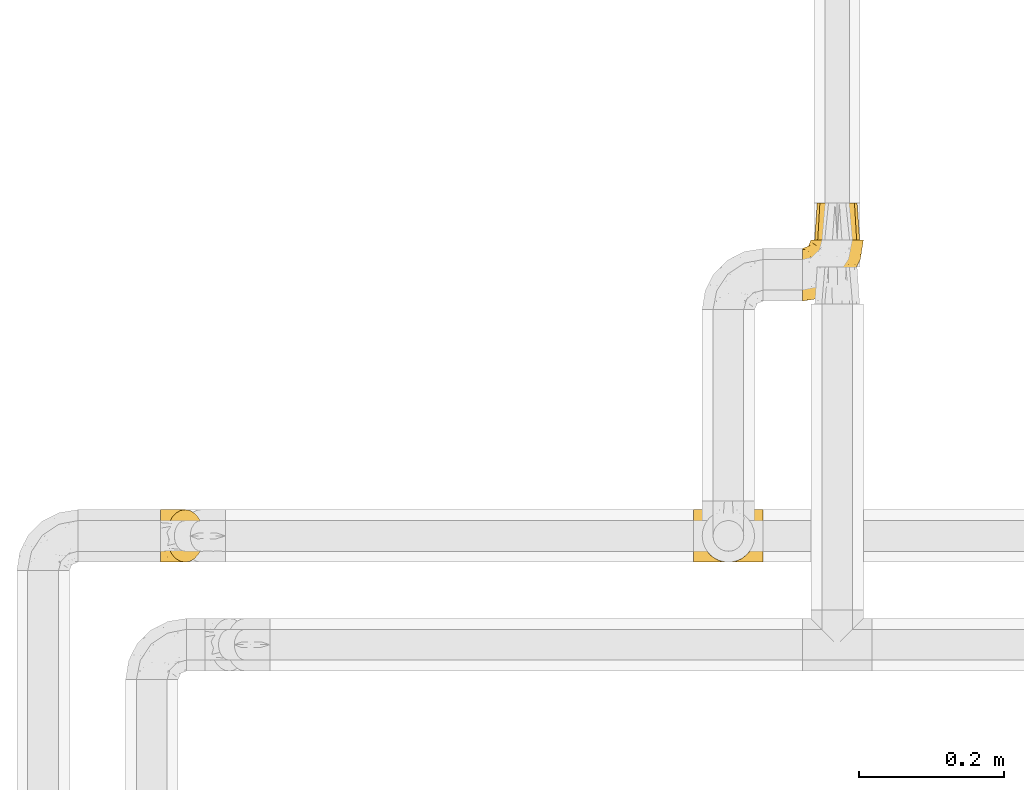
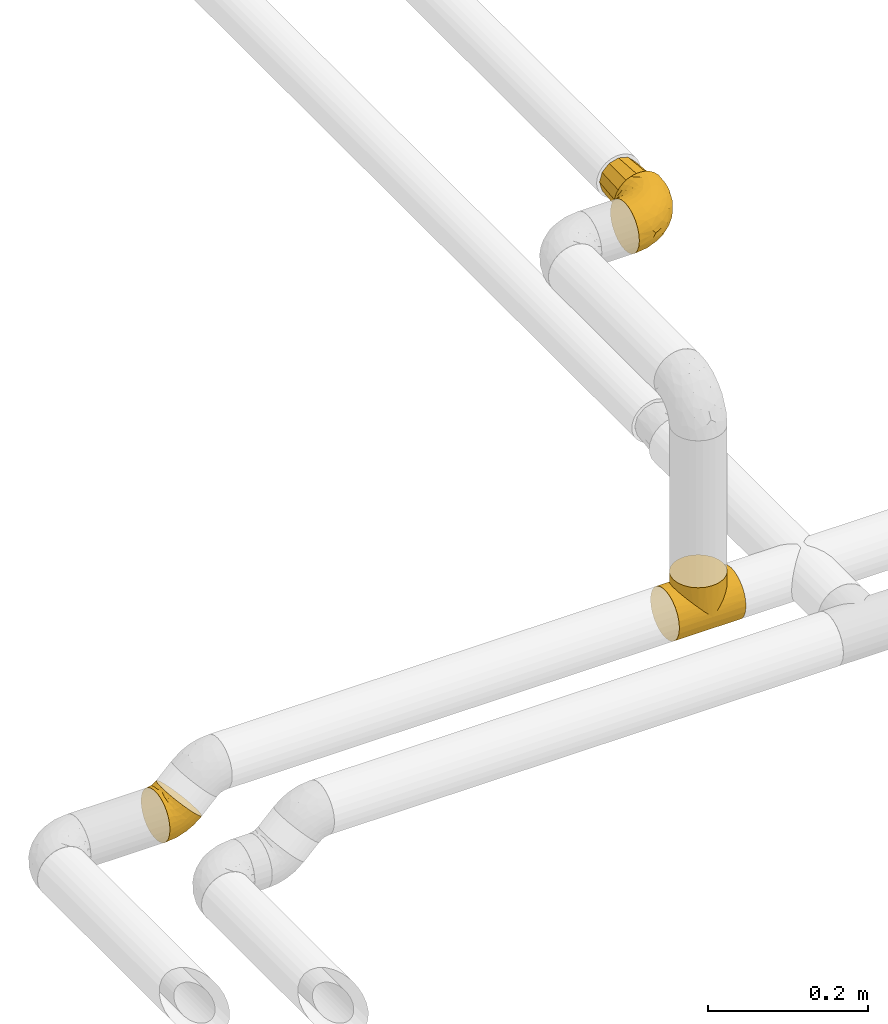
# One storey, part 20 of 39: 4 coverings.
"""IFC2X3 building model written with IfcOpenShell, lengths in millimetres."""

from ifc_helpers import new_model, entity, si_unit, converted_unit, derived_unit, direction, frame, origin, place, context, subcontext, project, spatial, faceted_brep, element, save


model = new_model("IFC2X3")

# Units and contexts
model_context = context("Model", 3, precision=0.01, world=origin(), true_north=direction((6.12303176911189e-17, 1.0)))
body_context = subcontext(model_context, "Body", "Model", "MODEL_VIEW")
ifc_project = project(units=[si_unit("LENGTHUNIT", "METRE", prefix="MILLI"), si_unit("AREAUNIT", "SQUARE_METRE"), si_unit("VOLUMEUNIT", "CUBIC_METRE"), converted_unit("PLANEANGLEUNIT", "DEGREE", entity("IfcRatioMeasure", 0.0174532925199433), si_unit("PLANEANGLEUNIT", "RADIAN"), dimensions=[0, 0, 0, 0, 0, 0, 0]), si_unit("MASSUNIT", "GRAM", prefix="KILO"), derived_unit("MASSDENSITYUNIT", [(si_unit("MASSUNIT", "GRAM", prefix="KILO"), 1), (si_unit("LENGTHUNIT", "METRE"), -3)]), derived_unit("MOMENTOFINERTIAUNIT", [(si_unit("LENGTHUNIT", "METRE"), 4)]), si_unit("TIMEUNIT", "SECOND"), si_unit("FREQUENCYUNIT", "HERTZ"), si_unit("THERMODYNAMICTEMPERATUREUNIT", "DEGREE_CELSIUS"), derived_unit("THERMALTRANSMITTANCEUNIT", [(si_unit("MASSUNIT", "GRAM", prefix="KILO"), 1), (si_unit("THERMODYNAMICTEMPERATUREUNIT", "KELVIN"), -1), (si_unit("TIMEUNIT", "SECOND"), -3)]), derived_unit("VOLUMETRICFLOWRATEUNIT", [(si_unit("LENGTHUNIT", "METRE"), 3), (si_unit("TIMEUNIT", "SECOND"), -1)]), derived_unit("MASSFLOWRATEUNIT", [(si_unit("MASSUNIT", "GRAM", prefix="KILO"), 1), (si_unit("TIMEUNIT", "SECOND"), -1)]), derived_unit("ROTATIONALFREQUENCYUNIT", [(si_unit("TIMEUNIT", "SECOND"), -1)]), si_unit("ELECTRICCURRENTUNIT", "AMPERE"), si_unit("ELECTRICVOLTAGEUNIT", "VOLT"), si_unit("POWERUNIT", "WATT"), si_unit("FORCEUNIT", "NEWTON", prefix="KILO"), si_unit("ILLUMINANCEUNIT", "LUX"), si_unit("LUMINOUSFLUXUNIT", "LUMEN"), si_unit("LUMINOUSINTENSITYUNIT", "CANDELA"), derived_unit("USERDEFINED", [(si_unit("MASSUNIT", "GRAM", prefix="KILO"), -1), (si_unit("LENGTHUNIT", "METRE"), -2), (si_unit("TIMEUNIT", "SECOND"), 3), (si_unit("LUMINOUSFLUXUNIT", "LUMEN"), 1)]), derived_unit("LINEARVELOCITYUNIT", [(si_unit("LENGTHUNIT", "METRE"), 1), (si_unit("TIMEUNIT", "SECOND"), -1)]), si_unit("PRESSUREUNIT", "PASCAL"), derived_unit("USERDEFINED", [(si_unit("LENGTHUNIT", "METRE"), -2), (si_unit("MASSUNIT", "GRAM", prefix="KILO"), 1), (si_unit("TIMEUNIT", "SECOND"), -2)]), derived_unit("LINEARFORCEUNIT", [(si_unit("MASSUNIT", "GRAM", prefix="KILO"), 1), (si_unit("LENGTHUNIT", "METRE"), 1), (si_unit("TIMEUNIT", "SECOND"), -2), (si_unit("LENGTHUNIT", "METRE"), -1)]), derived_unit("PLANARFORCEUNIT", [(si_unit("MASSUNIT", "GRAM", prefix="KILO"), 1), (si_unit("LENGTHUNIT", "METRE"), 1), (si_unit("TIMEUNIT", "SECOND"), -2), (si_unit("LENGTHUNIT", "METRE"), -2)])], contexts=[model_context])

# Site, building, storey
site_placement = place(None, origin())
site = spatial("IfcSite", under=ifc_project, at=site_placement, CompositionType="ELEMENT")
building_placement = place(site_placement, origin())
building = spatial("IfcBuilding", under=site, at=building_placement, CompositionType="ELEMENT")
storey_placement = place(building_placement, frame((0.0, 0.0, 24000.0)))
storey = spatial("IfcBuildingStorey", under=building, at=storey_placement, Name="07", CompositionType="ELEMENT", Elevation=24000.0)

# Coverings
covering_1_placement = place(storey_placement, frame((68680.48, 2837.56, 2992.18)))
element("IfcCovering", 1, at=covering_1_placement, inside=storey, Name=":ADSK_", ObjectType=":ADSK_", PredefinedType="INSULATION", context=body_context, shape_type="Brep", body=[
    faceted_brep([(1.61, 70.41, 53.5), (1.61, 73.09, 45.85), (1.6, 74.0, 37.8), (1.6, 73.09, 29.74), (1.6, 70.41, 22.08), (1.6, 66.09, 15.22), (1.6, 60.36, 9.49), (1.6, 53.5, 5.18), (1.6, 45.85, 2.5), (1.6, 37.8, 1.6), (1.6, 29.74, 2.5), (1.6, 22.08, 5.18), (1.6, 15.22, 9.5), (1.6, 9.49, 15.23), (1.6, 5.18, 22.09), (1.6, 2.5, 29.74), (1.6, 1.6, 37.8), (1.6, 2.5, 45.85), (1.61, 5.18, 53.51), (1.61, 9.5, 60.37), (1.61, 15.23, 66.1), (1.61, 22.09, 70.41), (1.61, 29.75, 73.09), (1.61, 37.8, 74.0), (1.61, 45.86, 73.09), (1.61, 53.51, 70.41), (1.61, 60.37, 66.09), (1.61, 66.1, 60.36), (35.55, 74.0, 51.85), (28.93, 72.76, 58.48), (22.75, 69.15, 64.65), (17.45, 63.39, 69.95), (13.39, 55.9, 74.02), (10.83, 47.17, 76.58), (9.96, 37.8, 77.45), (10.83, 28.43, 76.58), (13.39, 19.7, 74.02), (17.45, 12.2, 69.95), (22.75, 6.45, 64.65), (28.93, 2.83, 58.48), (35.55, 1.6, 51.85), (42.17, 2.83, 45.22), (48.35, 6.44, 39.05), (53.65, 12.2, 33.75), (57.72, 19.69, 29.68), (60.27, 28.43, 27.12), (61.15, 37.79, 26.25), (60.27, 47.16, 27.12), (57.72, 55.89, 29.68), (53.65, 63.39, 33.75), (48.35, 69.15, 39.05), (42.18, 72.76, 45.22), (18.39, 62.67, 13.41), (43.7, 37.8, 12.87), (50.18, 46.33, 18.27), (44.59, 59.22, 21.69), (23.39, 37.8, 4.46), (38.67, 47.22, 11.58), (41.04, 65.01, 25.7), (19.86, 49.2, 5.49), (31.54, 55.86, 12.28), (27.45, 67.36, 21.94), (32.38, 61.8, 17.29), (34.38, 70.8, 32.14), (28.93, 73.25, 37.71), (18.25, 71.45, 26.76), (47.67, 52.48, 19.06), (19.98, 74.0, 41.45), (15.02, 73.45, 33.24), (15.75, 56.5, 8.08), (13.47, 67.97, 18.84), (7.06, 74.0, 38.88), (12.52, 74.0, 39.96), (26.3, 74.0, 45.67), (30.92, 74.0, 48.76), (5.55, 44.65, 73.98), (6.54, 51.39, 72.21), (14.21, 71.74, 52.69), (18.21, 73.38, 47.93), (13.06, 73.3, 46.5), (11.6, 67.05, 61.05), (19.18, 72.18, 53.59), (17.71, 68.39, 62.09), (13.62, 63.72, 66.49), (24.23, 72.43, 55.92), (7.2, 73.06, 46.39), (10.05, 55.96, 71.4), (7.85, 59.5, 67.82), (8.72, 70.61, 53.87), (6.17, 65.15, 61.93), (6.13, 37.8, 74.89), (10.05, 19.65, 71.41), (13.63, 11.87, 66.49), (26.3, 1.6, 45.67), (19.18, 3.41, 53.59), (18.2, 2.21, 47.93), (6.53, 24.21, 72.21), (7.06, 1.6, 38.88), (7.84, 16.11, 67.83), (24.22, 3.16, 55.92), (30.92, 1.6, 48.76), (17.71, 7.2, 62.1), (8.72, 4.99, 53.88), (14.21, 3.86, 52.71), (11.59, 8.55, 61.06), (7.2, 2.54, 46.4), (13.08, 2.29, 46.51), (7.32, 30.7, 74.67), (12.52, 1.6, 39.96), (6.17, 10.45, 61.95), (19.97, 1.6, 41.45), (28.94, 2.34, 37.73), (18.25, 4.14, 26.77), (34.37, 4.79, 32.15), (18.39, 12.91, 13.42), (15.75, 19.08, 8.08), (31.54, 19.72, 12.29), (19.86, 26.38, 5.49), (50.18, 29.25, 18.27), (15.03, 2.14, 33.24), (38.69, 28.36, 11.59), (41.03, 10.58, 25.7), (44.6, 16.37, 21.69), (47.68, 23.1, 19.07), (27.44, 8.22, 21.95), (13.47, 7.62, 18.85), (32.38, 13.8, 17.28)], [[[0, 1, 2, 3, 4, 5, 6, 7, 8, 9, 10, 11, 12, 13, 14, 15, 16, 17, 18, 19, 20, 21, 22, 23, 24, 25, 26, 27]], [[28, 29, 30, 31, 32, 33, 34, 35, 36, 37, 38, 39, 40, 41, 42, 43, 44, 45, 46, 47, 48, 49, 50, 51]], [[5, 52, 6]], [[46, 53, 54]], [[48, 55, 49]], [[53, 56, 57]], [[58, 50, 49]], [[59, 60, 57]], [[61, 58, 62]], [[58, 63, 50]], [[64, 28, 51]], [[63, 61, 65]], [[54, 66, 47]], [[67, 64, 68]], [[55, 58, 49]], [[69, 52, 60]], [[59, 57, 56]], [[56, 8, 59]], [[7, 6, 69]], [[7, 69, 59]], [[65, 64, 63]], [[9, 8, 56]], [[70, 52, 5]], [[50, 63, 51]], [[60, 55, 66]], [[68, 2, 71, 72, 67]], [[4, 3, 65]], [[65, 61, 70]], [[59, 69, 60]], [[52, 69, 6]], [[4, 70, 5]], [[54, 57, 66]], [[3, 68, 65]], [[7, 59, 8]], [[64, 67, 73, 74, 28]], [[63, 64, 51]], [[66, 55, 48]], [[60, 52, 62]], [[65, 68, 64]], [[2, 68, 3]], [[62, 58, 55]], [[58, 61, 63]], [[60, 62, 55]], [[61, 62, 52]], [[47, 66, 48]], [[60, 66, 57]], [[65, 70, 4]], [[52, 70, 61]], [[46, 54, 47]], [[53, 57, 54]], [[75, 76, 24]], [[77, 78, 79]], [[80, 81, 77]], [[82, 83, 31]], [[84, 73, 81]], [[25, 24, 76]], [[85, 1, 0]], [[76, 75, 33]], [[86, 33, 32]], [[34, 33, 75]], [[86, 87, 76]], [[30, 84, 82]], [[78, 73, 67]], [[0, 88, 85]], [[89, 88, 27]], [[0, 27, 88]], [[85, 72, 71]], [[2, 1, 71]], [[29, 84, 30]], [[30, 82, 31]], [[73, 84, 74]], [[90, 75, 23]], [[72, 85, 79]], [[89, 87, 80]], [[25, 87, 26]], [[85, 71, 1]], [[25, 76, 87]], [[83, 32, 31]], [[77, 79, 88]], [[26, 89, 27]], [[67, 72, 79]], [[79, 85, 88]], [[87, 89, 26]], [[88, 89, 80]], [[81, 80, 82]], [[83, 82, 80]], [[80, 77, 88]], [[78, 77, 81]], [[80, 87, 83]], [[83, 87, 86]], [[73, 78, 81]], [[79, 78, 67]], [[29, 74, 84]], [[82, 84, 81]], [[29, 28, 74]], [[23, 75, 24]], [[75, 90, 34]], [[33, 86, 76]], [[83, 86, 32]], [[36, 91, 92]], [[93, 94, 95]], [[22, 21, 96]], [[17, 16, 97]], [[91, 35, 96]], [[21, 20, 98]], [[99, 100, 39]], [[101, 38, 37]], [[102, 103, 104]], [[94, 99, 101]], [[102, 105, 106]], [[91, 96, 98]], [[34, 90, 107]], [[103, 95, 94]], [[90, 23, 22]], [[92, 91, 98]], [[96, 21, 98]], [[97, 108, 105]], [[99, 39, 38]], [[98, 20, 109]], [[109, 20, 19]], [[102, 19, 18]], [[92, 104, 101]], [[17, 105, 18]], [[106, 103, 102]], [[105, 17, 97]], [[107, 96, 35]], [[109, 102, 104]], [[102, 18, 105]], [[96, 107, 22]], [[108, 110, 106]], [[106, 105, 108]], [[102, 109, 19]], [[98, 109, 104]], [[92, 101, 37]], [[104, 94, 101]], [[95, 106, 110]], [[104, 103, 94]], [[36, 92, 37]], [[98, 104, 92]], [[106, 95, 103]], [[93, 95, 110]], [[101, 99, 38]], [[93, 99, 94]], [[100, 99, 93]], [[100, 40, 39]], [[35, 91, 36]], [[34, 107, 35]], [[22, 107, 90]], [[111, 112, 113]], [[114, 115, 116]], [[111, 40, 100, 93, 110]], [[114, 13, 12]], [[117, 115, 11]], [[42, 41, 113]], [[45, 118, 46]], [[111, 110, 119]], [[117, 120, 116]], [[111, 113, 41]], [[121, 42, 113]], [[44, 122, 123]], [[40, 111, 41]], [[43, 122, 44]], [[14, 112, 15]], [[113, 124, 121]], [[112, 14, 125]], [[45, 123, 118]], [[125, 14, 13]], [[113, 112, 124]], [[112, 111, 119]], [[124, 125, 114]], [[120, 117, 56]], [[115, 12, 11]], [[10, 9, 56]], [[120, 56, 53]], [[10, 56, 117]], [[115, 117, 116]], [[115, 114, 12]], [[10, 117, 11]], [[126, 116, 122]], [[119, 16, 15]], [[123, 45, 44]], [[122, 121, 126]], [[121, 122, 43]], [[123, 116, 120]], [[119, 110, 108, 97, 16]], [[112, 119, 15]], [[42, 121, 43]], [[126, 124, 114]], [[124, 126, 121]], [[116, 126, 114]], [[116, 123, 122]], [[123, 120, 118]], [[114, 125, 13]], [[112, 125, 124]], [[120, 53, 118]], [[46, 118, 53]]]),
])
covering_2_placement = place(storey_placement, frame((69565.42, 3197.56, 3362.2)))
element("IfcCovering", 2, at=covering_2_placement, inside=storey, Name=":ADSK_", ObjectType=":ADSK_", PredefinedType="INSULATION", context=body_context, shape_type="Brep", body=[
    faceted_brep([(49.6, 85.8, 74.0), (57.65, 85.8, 73.09), (65.31, 85.8, 70.41), (72.17, 85.8, 66.09), (77.9, 85.8, 60.36), (82.21, 85.8, 53.5), (84.89, 85.8, 45.85), (85.8, 85.8, 37.8), (84.89, 85.8, 29.74), (82.21, 85.8, 22.08), (77.89, 85.8, 15.22), (72.16, 85.8, 9.49), (65.3, 85.8, 5.18), (57.65, 85.8, 2.5), (49.6, 85.8, 1.6), (44.33, 85.8, 2.19), (41.54, 85.8, 2.5), (37.71, 85.8, 3.84), (33.88, 85.8, 5.18), (27.02, 85.8, 9.5), (21.29, 85.8, 15.23), (16.98, 85.8, 22.09), (14.3, 85.8, 29.74), (13.4, 85.8, 37.8), (14.3, 85.8, 45.85), (16.98, 85.8, 53.51), (21.3, 85.8, 60.37), (27.03, 85.8, 66.1), (33.89, 85.8, 70.41), (37.72, 85.8, 71.75), (41.54, 85.8, 73.09), (44.33, 85.8, 73.4), (1.6, 72.76, 28.43), (1.6, 69.15, 19.7), (1.6, 63.39, 12.2), (1.6, 59.64, 9.32), (1.6, 55.9, 6.45), (1.6, 51.53, 4.64), (1.6, 47.16, 2.83), (1.6, 43.08, 2.29), (1.6, 40.44, 1.94), (1.6, 37.8, 1.6), (1.6, 28.43, 2.83), (1.6, 19.7, 6.45), (1.6, 12.2, 12.2), (1.6, 6.45, 19.7), (1.6, 2.83, 28.43), (1.6, 1.6, 37.8), (1.6, 2.83, 47.16), (1.6, 6.45, 55.9), (1.6, 12.2, 63.39), (1.6, 19.7, 69.15), (1.6, 28.43, 72.76), (1.6, 37.8, 74.0), (1.6, 43.08, 73.3), (1.6, 47.16, 72.76), (1.6, 51.53, 70.95), (1.6, 55.9, 69.15), (1.6, 59.64, 66.27), (1.6, 63.39, 63.39), (1.6, 69.15, 55.9), (1.6, 72.76, 47.16), (1.6, 74.0, 37.8), (59.61, 27.78, 50.11), (60.4, 26.99, 37.8), (68.25, 36.07, 46.44), (27.61, 5.72, 37.8), (22.94, 4.9, 44.03), (19.4, 4.42, 37.8), (42.09, 13.52, 47.59), (33.53, 14.0, 57.17), (21.38, 6.28, 50.38), (16.47, 9.64, 58.65), (54.23, 70.93, 73.37), (38.23, 36.05, 71.27), (19.11, 24.02, 70.16), (36.76, 25.93, 66.97), (17.03, 32.56, 73.22), (19.96, 41.45, 74.0), (12.51, 39.97, 74.0), (9.78, 39.42, 74.0), (7.05, 38.88, 74.0), (21.71, 16.62, 64.86), (62.55, 71.64, 70.93), (75.89, 47.83, 45.19), (81.72, 65.91, 48.57), (74.04, 51.38, 54.32), (47.66, 52.81, 72.94), (45.94, 67.43, 74.0), (43.34, 63.53, 74.0), (40.74, 59.64, 74.0), (38.14, 55.75, 74.0), (35.54, 51.85, 74.0), (51.41, 41.26, 68.72), (30.21, 38.98, 73.34), (68.91, 70.65, 67.28), (74.03, 65.64, 61.7), (79.54, 71.08, 55.94), (82.98, 67.99, 37.8), (67.24, 38.62, 53.02), (55.48, 28.73, 57.31), (48.51, 80.34, 74.0), (47.42, 74.88, 74.0), (65.49, 52.52, 64.86), (64.99, 41.68, 59.15), (58.95, 56.44, 70.05), (45.7, 19.89, 55.98), (39.35, 11.7, 37.8), (53.72, 34.04, 63.54), (42.9, 22.66, 61.4), (81.67, 59.78, 37.8), (69.71, 36.3, 37.8), (75.69, 48.04, 37.8), (31.64, 49.25, 74.0), (27.75, 46.65, 74.0), (23.86, 44.05, 74.0), (51.09, 17.68, 37.8), (17.47, 56.47, 70.9), (18.36, 60.92, 69.2), (12.71, 63.29, 65.83), (7.84, 45.31, 73.31), (7.85, 59.83, 67.07), (6.14, 64.71, 62.53), (11.2, 74.49, 52.3), (14.99, 76.83, 54.94), (11.85, 78.01, 46.54), (23.69, 56.9, 72.08), (20.48, 50.18, 73.17), (14.49, 71.99, 59.32), (9.51, 70.83, 56.36), (6.6, 73.18, 48.99), (6.61, 68.29, 58.36), (26.46, 80.74, 66.05), (20.83, 78.17, 61.56), (28.69, 73.83, 68.98), (41.38, 76.96, 73.26), (7.16, 54.72, 70.05), (16.97, 47.37, 73.39), (12.64, 54.39, 70.87), (18.4, 74.3, 61.17), (35.97, 75.54, 71.9), (16.38, 66.46, 65.19), (11.31, 80.75, 37.8), (13.68, 81.71, 46.04), (15.78, 81.69, 52.15), (24.06, 72.63, 66.57), (9.94, 77.45, 37.8), (35.3, 62.19, 73.34), (36.41, 67.73, 72.91), (6.64, 76.08, 37.8), (10.52, 48.26, 72.75), (23.5, 62.83, 70.14), (29.62, 62.31, 72.14), (20.86, 68.86, 66.28), (29.66, 56.53, 73.22), (6.61, 68.29, 17.23), (6.59, 73.17, 26.6), (6.13, 64.71, 13.06), (48.51, 80.34, 1.6), (47.42, 74.88, 1.6), (13.67, 81.71, 29.56), (14.98, 76.83, 20.66), (15.78, 81.69, 23.45), (20.82, 78.17, 14.04), (12.51, 39.97, 1.6), (7.05, 38.88, 1.6), (4.32, 38.34, 1.6), (9.51, 70.83, 19.23), (11.19, 74.49, 23.3), (14.48, 72.0, 16.29), (10.19, 59.87, 8.09), (12.64, 54.39, 4.72), (7.16, 54.72, 5.54), (35.96, 75.53, 3.69), (10.52, 48.26, 2.84), (20.47, 50.18, 2.42), (17.47, 56.47, 4.69), (23.68, 56.9, 3.51), (16.97, 47.37, 2.2), (11.85, 78.01, 29.05), (7.84, 45.31, 2.29), (26.45, 80.74, 9.55), (18.39, 74.3, 14.43), (41.37, 76.96, 2.33), (29.62, 62.32, 3.45), (29.66, 56.54, 2.37), (23.5, 62.83, 5.45), (16.36, 66.46, 10.41), (35.87, 67.82, 2.81), (28.67, 73.83, 6.62), (45.94, 67.43, 1.6), (12.7, 63.29, 9.76), (24.04, 72.63, 9.03), (38.14, 55.75, 1.6), (30.95, 67.39, 4.15), (35.8, 62.12, 2.17), (43.34, 63.53, 1.6), (27.75, 46.65, 1.6), (31.64, 49.25, 1.6), (19.96, 41.45, 1.6), (23.86, 44.05, 1.6), (18.36, 60.93, 6.39), (20.85, 68.85, 9.32), (40.74, 59.64, 1.6), (35.54, 51.85, 1.6), (38.23, 36.06, 4.32), (17.03, 32.56, 2.37), (30.2, 38.98, 2.25), (64.98, 41.69, 16.43), (55.47, 28.73, 18.27), (53.71, 34.05, 12.04), (36.76, 25.93, 8.62), (51.4, 41.26, 6.87), (65.48, 52.53, 10.72), (47.66, 52.81, 2.64), (59.61, 27.78, 25.48), (45.69, 19.9, 19.59), (19.11, 24.02, 5.43), (22.94, 4.9, 31.57), (21.39, 6.28, 25.21), (58.94, 56.45, 5.53), (16.47, 9.64, 16.94), (21.71, 16.62, 10.73), (33.54, 14.0, 18.42), (74.04, 51.38, 21.26), (81.72, 65.91, 27.01), (75.89, 47.82, 30.39), (54.23, 70.94, 2.22), (74.02, 65.64, 13.88), (68.9, 70.65, 8.3), (42.09, 13.52, 28.0), (68.25, 36.08, 29.14), (67.24, 38.62, 22.56), (79.54, 71.07, 19.64), (42.91, 22.68, 14.18), (62.54, 71.64, 4.66)], [[[0, 1, 2, 3, 4, 5, 6, 7, 8, 9, 10, 11, 12, 13, 14, 15, 16, 17, 18, 19, 20, 21, 22, 23, 24, 25, 26, 27, 28, 29, 30, 31]], [[32, 33, 34, 35, 36, 37, 38, 39, 40, 41, 42, 43, 44, 45, 46, 47, 48, 49, 50, 51, 52, 53, 54, 55, 56, 57, 58, 59, 60, 61, 62]], [[63, 64, 65]], [[66, 67, 68]], [[69, 70, 71]], [[71, 70, 72]], [[73, 1, 0]], [[74, 75, 76]], [[49, 48, 71]], [[77, 78, 79, 80, 81, 53]], [[50, 82, 51]], [[72, 50, 49]], [[2, 1, 83]], [[84, 85, 86]], [[87, 88, 89, 90, 91, 92]], [[53, 52, 77]], [[93, 74, 76]], [[5, 85, 6]], [[94, 78, 77]], [[95, 3, 2]], [[95, 96, 3]], [[75, 51, 82]], [[85, 5, 97]], [[50, 72, 82]], [[97, 5, 4]], [[85, 98, 6]], [[94, 87, 92]], [[74, 77, 75]], [[99, 100, 63]], [[96, 4, 3]], [[73, 0, 101, 102, 88]], [[96, 103, 104]], [[48, 68, 67]], [[84, 99, 65]], [[105, 83, 73]], [[105, 95, 83]], [[100, 106, 63]], [[86, 96, 104]], [[97, 86, 85]], [[67, 107, 69]], [[100, 108, 109]], [[84, 110, 85]], [[93, 87, 74]], [[96, 95, 103]], [[69, 71, 67]], [[70, 69, 106]], [[4, 96, 97]], [[86, 97, 96]], [[83, 95, 2]], [[103, 95, 105]], [[93, 103, 105]], [[103, 108, 104]], [[75, 77, 52]], [[94, 77, 74]], [[51, 75, 52]], [[75, 82, 76]], [[109, 82, 70]], [[93, 76, 108]], [[88, 87, 73]], [[105, 73, 87]], [[84, 86, 99]], [[84, 111, 112, 110]], [[98, 85, 110]], [[98, 7, 6]], [[73, 83, 1]], [[71, 72, 49]], [[82, 72, 70]], [[87, 94, 74]], [[94, 92, 113, 114, 115, 78]], [[48, 47, 68]], [[48, 67, 71]], [[100, 104, 108]], [[99, 86, 104]], [[109, 108, 76]], [[100, 109, 106]], [[82, 109, 76]], [[106, 109, 70]], [[100, 99, 104]], [[99, 63, 65]], [[69, 116, 63]], [[111, 84, 65]], [[64, 63, 116]], [[64, 111, 65]], [[63, 106, 69]], [[103, 93, 108]], [[87, 93, 105]], [[107, 67, 66]], [[107, 116, 69]], [[117, 118, 119]], [[80, 120, 55]], [[121, 119, 122]], [[120, 56, 55]], [[123, 124, 125]], [[114, 126, 127]], [[101, 0, 31, 30, 102]], [[123, 128, 124]], [[129, 123, 130]], [[60, 122, 131]], [[132, 133, 134]], [[29, 28, 135]], [[131, 61, 60]], [[122, 60, 59]], [[136, 137, 138]], [[124, 128, 139]], [[132, 27, 26]], [[131, 130, 61]], [[140, 135, 28]], [[102, 29, 135]], [[119, 118, 141]], [[58, 136, 121]], [[140, 28, 27]], [[54, 53, 81, 80, 55]], [[23, 142, 143]], [[24, 144, 25]], [[25, 144, 133]], [[26, 25, 133]], [[134, 133, 145]], [[125, 142, 146]], [[124, 143, 125]], [[147, 90, 148]], [[124, 144, 143]], [[149, 125, 146]], [[150, 57, 56]], [[137, 78, 115]], [[130, 62, 61]], [[132, 140, 27]], [[151, 152, 153]], [[140, 134, 148]], [[148, 89, 140]], [[120, 78, 150]], [[115, 127, 137]], [[137, 136, 150]], [[78, 120, 80, 79]], [[150, 56, 120]], [[91, 154, 92]], [[127, 117, 138]], [[144, 24, 143]], [[133, 144, 124]], [[152, 91, 147]], [[145, 152, 134]], [[23, 143, 24]], [[142, 125, 143]], [[130, 125, 149]], [[128, 123, 129]], [[141, 129, 119]], [[124, 139, 133]], [[125, 130, 123]], [[62, 130, 149]], [[128, 153, 139]], [[145, 139, 153]], [[92, 154, 113]], [[127, 115, 114]], [[117, 127, 126]], [[118, 117, 126]], [[121, 117, 119]], [[138, 137, 127]], [[78, 137, 150]], [[151, 118, 126]], [[118, 151, 141]], [[153, 128, 141]], [[129, 141, 128]], [[102, 30, 29]], [[140, 88, 135]], [[88, 102, 135]], [[133, 132, 26]], [[140, 132, 134]], [[121, 122, 59]], [[131, 119, 129]], [[121, 59, 58]], [[121, 138, 117]], [[136, 58, 57]], [[150, 136, 57]], [[121, 136, 138]], [[119, 131, 122]], [[131, 129, 130]], [[139, 145, 133]], [[152, 145, 153]], [[89, 148, 90]], [[89, 88, 140]], [[147, 134, 152]], [[134, 147, 148]], [[126, 114, 113]], [[152, 154, 91]], [[91, 90, 147]], [[151, 153, 141]], [[154, 151, 126]], [[151, 154, 152]], [[113, 154, 126]], [[155, 32, 156]], [[33, 157, 34]], [[62, 149, 156]], [[15, 14, 158, 159, 16]], [[160, 23, 22]], [[161, 162, 163]], [[40, 39, 38, 164, 165, 166, 41]], [[167, 168, 169]], [[157, 170, 34]], [[171, 172, 170]], [[18, 173, 19]], [[174, 37, 36]], [[175, 176, 177]], [[178, 171, 175]], [[146, 179, 149]], [[168, 179, 161]], [[161, 160, 162]], [[162, 160, 22]], [[38, 37, 180]], [[20, 19, 181]], [[21, 20, 163]], [[161, 182, 169]], [[18, 183, 173]], [[184, 185, 186]], [[169, 187, 167]], [[188, 189, 173]], [[159, 190, 183]], [[17, 159, 183]], [[156, 179, 168]], [[191, 157, 155]], [[192, 163, 189]], [[21, 162, 22]], [[146, 142, 179]], [[181, 163, 20]], [[185, 184, 193]], [[178, 172, 171]], [[167, 156, 168]], [[184, 194, 195]], [[181, 173, 189]], [[173, 196, 188]], [[197, 177, 198]], [[199, 164, 180]], [[180, 164, 38]], [[200, 178, 175]], [[37, 174, 180]], [[199, 180, 174]], [[175, 197, 200]], [[177, 176, 201]], [[163, 162, 21]], [[160, 161, 179]], [[192, 184, 202]], [[194, 189, 188]], [[179, 142, 160]], [[23, 160, 142]], [[169, 168, 161]], [[155, 156, 167]], [[182, 161, 163]], [[202, 186, 187]], [[62, 156, 32]], [[179, 156, 149]], [[192, 182, 163]], [[202, 169, 182]], [[176, 175, 171]], [[174, 178, 199]], [[197, 175, 177]], [[170, 176, 171]], [[201, 176, 191]], [[199, 178, 200]], [[178, 174, 172]], [[187, 201, 191]], [[201, 187, 186]], [[167, 187, 191]], [[169, 202, 187]], [[173, 183, 190]], [[17, 16, 159]], [[173, 181, 19]], [[163, 181, 189]], [[155, 157, 33]], [[170, 157, 191]], [[176, 170, 191]], [[35, 170, 172]], [[35, 172, 36]], [[34, 170, 35]], [[174, 36, 172]], [[32, 155, 33]], [[191, 155, 167]], [[192, 189, 194]], [[182, 192, 202]], [[185, 198, 177]], [[183, 18, 17]], [[196, 173, 190]], [[196, 203, 188]], [[201, 186, 177]], [[202, 184, 186]], [[188, 195, 194]], [[204, 185, 193]], [[188, 203, 195]], [[192, 194, 184]], [[203, 193, 195]], [[184, 195, 193]], [[198, 185, 204]], [[186, 185, 177]], [[205, 206, 207]], [[208, 209, 210]], [[210, 211, 212]], [[210, 213, 208]], [[214, 204, 193, 203, 196, 190]], [[206, 41, 166, 165, 164, 199]], [[215, 216, 209]], [[206, 217, 42]], [[218, 46, 219]], [[207, 214, 205]], [[212, 214, 220]], [[221, 219, 45]], [[45, 219, 46]], [[221, 222, 223]], [[224, 225, 226]], [[222, 44, 43]], [[222, 217, 211]], [[220, 214, 227]], [[227, 190, 159, 158, 14]], [[217, 43, 42]], [[14, 13, 227]], [[225, 9, 8]], [[10, 228, 11]], [[11, 229, 12]], [[208, 213, 228]], [[228, 229, 11]], [[230, 219, 223]], [[231, 232, 226]], [[231, 64, 215]], [[225, 233, 9]], [[229, 213, 220]], [[233, 10, 9]], [[110, 225, 98]], [[41, 206, 42]], [[222, 211, 234]], [[224, 228, 233]], [[225, 8, 98]], [[221, 45, 44]], [[226, 110, 112, 111]], [[12, 229, 235]], [[46, 218, 68]], [[230, 107, 218]], [[223, 234, 216]], [[107, 66, 218]], [[224, 233, 225]], [[228, 10, 233]], [[213, 229, 228]], [[235, 229, 220]], [[208, 228, 224]], [[212, 213, 210]], [[207, 206, 199]], [[205, 211, 217]], [[205, 217, 206]], [[43, 217, 222]], [[212, 211, 205]], [[210, 209, 234]], [[227, 13, 235]], [[214, 190, 227]], [[110, 226, 225]], [[232, 231, 215]], [[8, 7, 98]], [[227, 235, 220]], [[13, 12, 235]], [[222, 221, 44]], [[219, 221, 223]], [[207, 199, 200, 197, 198, 204]], [[214, 207, 204]], [[68, 218, 66]], [[68, 47, 46]], [[230, 218, 219]], [[224, 232, 208]], [[208, 232, 209]], [[216, 215, 230]], [[210, 234, 211]], [[216, 234, 209]], [[222, 234, 223]], [[226, 232, 224]], [[209, 232, 215]], [[226, 111, 231]], [[64, 116, 215]], [[231, 111, 64]], [[116, 230, 215]], [[230, 223, 216]], [[214, 212, 205]], [[213, 212, 220]], [[230, 116, 107]]]),
])
covering_3_placement = place(storey_placement, frame((69582.42, 3283.35, 3367.4)))
element("IfcCovering", 3, at=covering_3_placement, inside=storey, Name=":ADSK_", ObjectType=":ADSK_", PredefinedType="INSULATION", context=body_context, shape_type="Brep", body=[
    faceted_brep([(56.41, 51.0, 46.35), (58.25, 51.0, 39.47), (60.1, 51.0, 32.6), (58.25, 51.0, 25.72), (56.41, 51.0, 18.85), (51.38, 51.0, 13.81), (46.35, 51.0, 8.78), (39.47, 51.0, 6.94), (32.6, 51.0, 5.1), (25.72, 51.0, 6.94), (18.85, 51.0, 8.78), (13.81, 51.0, 13.81), (8.78, 51.0, 18.85), (6.94, 51.0, 25.72), (5.1, 51.0, 32.6), (6.94, 51.0, 39.47), (8.78, 51.0, 46.35), (13.81, 51.0, 51.38), (18.85, 51.0, 56.41), (25.72, 51.0, 58.25), (32.6, 51.0, 60.1), (39.47, 51.0, 58.25), (46.35, 51.0, 56.41), (51.38, 51.0, 51.38), (11.42, 0.0, 53.77), (5.75, 0.0, 48.1), (4.15, 0.0, 42.14), (1.6, 0.0, 32.6), (4.15, 0.0, 23.05), (5.75, 0.0, 17.1), (11.42, 0.0, 11.42), (17.1, 0.0, 5.75), (23.05, 0.0, 4.15), (32.6, 0.0, 1.6), (42.14, 0.0, 4.15), (48.1, 0.0, 5.75), (53.77, 0.0, 11.42), (59.44, 0.0, 17.1), (61.04, 0.0, 23.05), (63.6, 0.0, 32.6), (61.04, 0.0, 42.14), (59.44, 0.0, 48.1), (53.77, 0.0, 53.77), (48.1, 0.0, 59.44), (42.14, 0.0, 61.04), (32.6, 0.0, 63.6), (23.05, 0.0, 61.04), (17.1, 0.0, 59.44)], [[[0, 1, 2, 3, 4, 5, 6, 7, 8, 9, 10, 11, 12, 13, 14, 15, 16, 17, 18, 19, 20, 21, 22, 23]], [[24, 25, 26, 27, 28, 29, 30, 31, 32, 33, 34, 35, 36, 37, 38, 39, 40, 41, 42, 43, 44, 45, 46, 47]], [[6, 35, 34, 33, 8, 7]], [[37, 36, 35, 6, 5, 4]], [[3, 2, 39, 38, 37, 4]], [[12, 29, 28, 27, 14, 13]], [[31, 30, 29, 12, 11, 10]], [[9, 8, 33, 32, 31, 10]], [[18, 47, 46, 45, 20, 19]], [[25, 24, 47, 18, 17, 16]], [[15, 14, 27, 26, 25, 16]], [[0, 41, 40, 39, 2, 1]], [[43, 42, 41, 0, 23, 22]], [[21, 20, 45, 44, 43, 22]]]),
])
covering_4_placement = place(storey_placement, frame((69417.01, 2837.56, 3042.2)))
element("IfcCovering", 4, at=covering_4_placement, inside=storey, Name=":ADSK_", ObjectType=":ADSK_", PredefinedType="INSULATION", context=body_context, shape_type="Brep", body=[
    faceted_brep([(41.92, 73.48, 43.88), (0.0, 74.0, 37.8), (0.0, 72.76, 47.16), (0.0, 69.15, 55.9), (35.92, 71.92, 49.87), (24.64, 65.45, 61.15), (0.0, 63.39, 63.39), (30.12, 69.27, 55.68), (48.0, 74.0, 37.8), (54.08, 73.48, 43.88), (96.0, 74.0, 37.8), (19.71, 60.38, 66.09), (0.0, 55.9, 69.15), (15.62, 53.98, 70.18), (0.0, 47.16, 72.76), (12.82, 46.31, 72.98), (0.0, 37.8, 74.0), (11.8, 37.8, 74.0), (83.18, 46.31, 72.98), (84.2, 37.8, 74.0), (96.0, 37.8, 74.0), (12.81, 29.29, 72.98), (0.0, 28.43, 72.76), (15.61, 21.62, 70.18), (0.0, 19.7, 69.15), (19.7, 15.22, 66.09), (0.0, 12.2, 63.39), (83.19, 29.29, 72.98), (24.64, 10.14, 61.16), (30.11, 6.33, 55.69), (0.0, 6.45, 55.9), (35.92, 3.67, 49.88), (0.0, 2.83, 47.16), (41.91, 2.11, 43.88), (0.0, 1.6, 37.8), (48.0, 1.6, 37.8), (54.09, 2.11, 43.88), (96.0, 1.6, 37.8), (96.0, 37.8, 1.6), (96.0, 47.16, 2.83), (96.0, 55.9, 6.45), (96.0, 63.39, 12.2), (96.0, 69.15, 19.7), (96.0, 72.76, 28.43), (96.0, 72.76, 47.16), (96.0, 69.15, 55.9), (96.0, 63.39, 63.39), (96.0, 55.9, 69.15), (96.0, 47.16, 72.76), (96.0, 28.43, 72.76), (96.0, 19.7, 69.15), (96.0, 12.2, 63.39), (96.0, 6.45, 55.9), (96.0, 2.83, 47.16), (96.0, 2.83, 28.43), (96.0, 6.45, 19.7), (96.0, 12.2, 12.2), (96.0, 19.7, 6.45), (96.0, 28.43, 2.83), (0.0, 47.16, 2.83), (0.0, 37.8, 1.6), (0.0, 28.43, 2.83), (0.0, 19.7, 6.45), (0.0, 12.2, 12.2), (0.0, 6.45, 19.7), (0.0, 2.83, 28.43), (0.0, 72.76, 28.43), (0.0, 69.15, 19.7), (0.0, 63.39, 12.2), (0.0, 55.9, 6.45), (60.08, 71.92, 49.87), (65.88, 69.27, 55.68), (71.36, 65.45, 61.15), (76.29, 60.38, 66.09), (80.38, 53.98, 70.18), (80.39, 21.62, 70.18), (76.3, 15.22, 66.09), (71.36, 10.14, 61.16), (65.89, 6.33, 55.69), (60.08, 3.67, 49.88), (13.03, 47.16, 85.8), (11.8, 37.8, 85.8), (13.03, 28.43, 85.8), (16.65, 19.7, 85.8), (22.4, 12.2, 85.8), (29.9, 6.45, 85.8), (38.63, 2.83, 85.8), (48.0, 1.6, 85.8), (57.37, 2.83, 85.8), (66.1, 6.45, 85.8), (73.6, 12.2, 85.8), (79.35, 19.7, 85.8), (82.97, 28.43, 85.8), (84.2, 37.8, 85.8), (82.97, 47.16, 85.8), (79.35, 55.9, 85.8), (73.6, 63.39, 85.8), (66.1, 69.15, 85.8), (57.37, 72.76, 85.8), (48.0, 74.0, 85.8), (38.63, 72.76, 85.8), (29.9, 69.15, 85.8), (22.4, 63.39, 85.8), (16.65, 55.9, 85.8)], [[[0, 1, 2]], [[2, 3, 4]], [[5, 3, 6]], [[5, 7, 3]], [[0, 8, 1]], [[8, 9, 10]], [[7, 4, 3]], [[0, 2, 4]], [[11, 6, 12]], [[13, 12, 14]], [[15, 14, 16]], [[13, 11, 12]], [[17, 15, 16]], [[18, 19, 20]], [[13, 14, 15]], [[6, 11, 5]], [[21, 16, 22]], [[23, 22, 24]], [[25, 24, 26]], [[21, 17, 16]], [[19, 27, 20]], [[25, 23, 24]], [[21, 22, 23]], [[26, 28, 25]], [[29, 28, 30]], [[30, 28, 26]], [[31, 30, 32]], [[33, 32, 34]], [[31, 29, 30]], [[35, 33, 34]], [[36, 35, 37]], [[31, 32, 33]], [[38, 39, 40, 41, 42, 43, 10, 44, 45, 46, 47, 48, 20, 49, 50, 51, 52, 53, 37, 54, 55, 56, 57, 58]], [[59, 60, 61, 62, 63, 64, 65, 34, 32, 30, 26, 24, 22, 16, 14, 12, 6, 3, 2, 1, 66, 67, 68, 69]], [[69, 68, 41, 40]], [[38, 60, 59, 39]], [[59, 69, 40, 39]], [[42, 67, 66, 43]], [[1, 8, 10, 43, 66]], [[41, 68, 67, 42]], [[70, 71, 45]], [[9, 70, 44]], [[10, 9, 44]], [[45, 72, 46]], [[45, 44, 70]], [[72, 45, 71]], [[73, 74, 47]], [[74, 18, 48]], [[46, 73, 47]], [[47, 74, 48]], [[18, 20, 48]], [[73, 46, 72]], [[75, 76, 50]], [[27, 75, 49]], [[20, 27, 49]], [[50, 49, 75]], [[51, 50, 76]], [[76, 77, 51]], [[78, 79, 52]], [[79, 36, 53]], [[77, 52, 51]], [[77, 78, 52]], [[52, 79, 53]], [[36, 37, 53]], [[35, 34, 65, 54, 37]], [[54, 65, 64, 55]], [[64, 63, 56, 55]], [[56, 63, 62, 57]], [[57, 62, 61, 58]], [[58, 61, 60, 38]], [[80, 81, 82, 83, 84, 85, 86, 87, 88, 89, 90, 91, 92, 93, 94, 95, 96, 97, 98, 99, 100, 101, 102, 103]], [[15, 81, 80]], [[103, 102, 11]], [[13, 80, 103]], [[15, 17, 81]], [[11, 13, 103]], [[15, 80, 13]], [[102, 5, 11]], [[7, 5, 101]], [[101, 5, 102]], [[4, 101, 100]], [[0, 100, 99]], [[4, 7, 101]], [[8, 0, 99]], [[4, 100, 0]], [[9, 99, 98]], [[98, 97, 70]], [[72, 97, 96]], [[72, 71, 97]], [[9, 8, 99]], [[71, 70, 97]], [[9, 98, 70]], [[73, 96, 95]], [[74, 95, 94]], [[18, 94, 93]], [[74, 73, 95]], [[19, 18, 93]], [[74, 94, 18]], [[96, 73, 72]], [[27, 93, 92]], [[75, 92, 91]], [[76, 91, 90]], [[27, 19, 93]], [[76, 75, 91]], [[27, 92, 75]], [[90, 77, 76]], [[78, 77, 89]], [[89, 77, 90]], [[79, 89, 88]], [[36, 88, 87]], [[79, 78, 89]], [[35, 36, 87]], [[79, 88, 36]], [[33, 87, 86]], [[86, 85, 31]], [[28, 85, 84]], [[28, 29, 85]], [[33, 35, 87]], [[29, 31, 85]], [[33, 86, 31]], [[25, 84, 83]], [[23, 83, 82]], [[21, 82, 81]], [[23, 25, 83]], [[17, 21, 81]], [[23, 82, 21]], [[84, 25, 28]]]),
])

save(model, "model.ifc")
